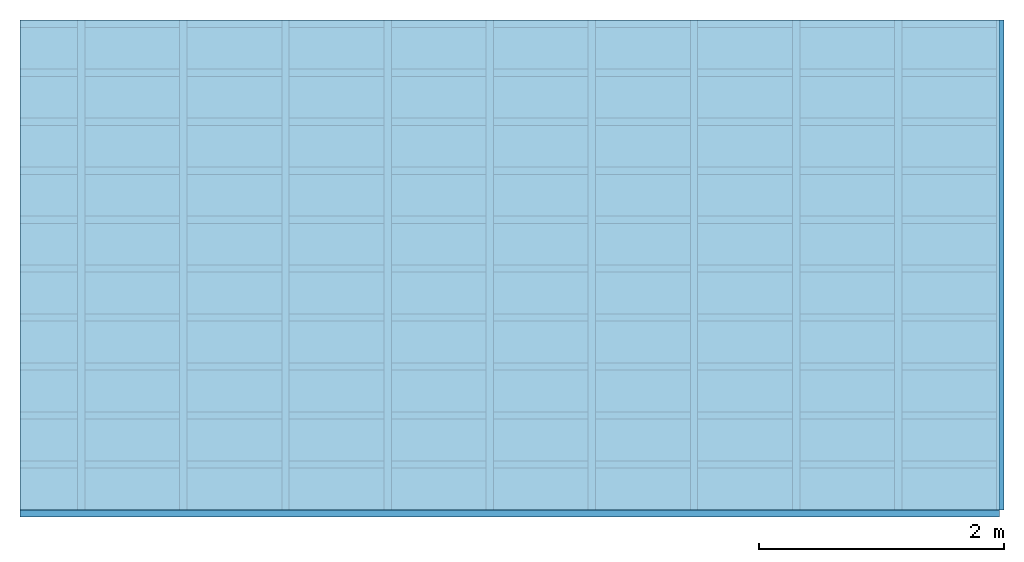
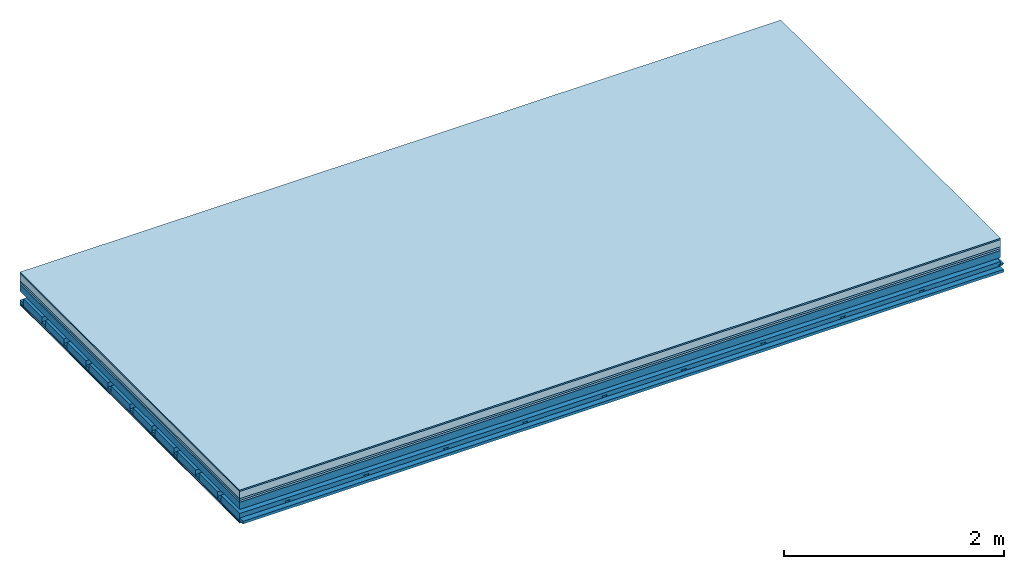
# One storey: 7 plates, 4 members, 1 element without a shape of its own.
"""IFC4 building model written with IfcOpenShell, lengths in metres."""

from ifc_helpers import new_model, si_unit, derived_unit, direction, frame, frame_2d, origin, origin_with_axes, place, context, project, spatial, polyline, rectangle, outline, extrude, material, layer, layer_set, type_object, element, aggregate, save


model = new_model("IFC4")

# Units and contexts
plan_context = context("Plan", 3, precision=1e-05, world=origin(), true_north=direction((0.0, 1.0)))
model_context = context("Model", 3, precision=1e-05, world=origin(), true_north=direction((0.0, 1.0)))
ifc_project = project(units=[si_unit("LENGTHUNIT", "METRE"), derived_unit("SOUNDPRESSUREUNIT", [(si_unit("PRESSUREUNIT", "PASCAL", prefix="MICRO"), 0)]), si_unit("ENERGYUNIT", "JOULE", prefix="MEGA"), si_unit("MASSUNIT", "GRAM", prefix="KILO"), derived_unit("THERMALTRANSMITTANCEUNIT", [(si_unit("POWERUNIT", "WATT"), 1), (si_unit("AREAUNIT", "SQUARE_METRE"), -1), (si_unit("THERMODYNAMICTEMPERATUREUNIT", "KELVIN"), -1)]), derived_unit("AREADENSITYUNIT", [(si_unit("MASSUNIT", "GRAM", prefix="KILO"), 1), (si_unit("AREAUNIT", "SQUARE_METRE"), -1)]), derived_unit("USERDEFINED", [(si_unit("ENERGYUNIT", "JOULE", prefix="MEGA"), 1), (si_unit("AREAUNIT", "SQUARE_METRE"), -1)])], contexts=[plan_context, model_context])

# Site, building, storey
site = spatial("IfcSite", under=ifc_project)
building_placement = place(None, origin())
building = spatial("IfcBuilding", under=site, at=building_placement)
storey_placement = place(building_placement, origin())
storey = spatial("IfcBuildingStorey", under=building, at=storey_placement)

# Slab, members, plates
ifc_material_1 = material(Category="11.013")
ifc_layer_1 = layer(ifc_material_1, 0.015, Name="Flooring")
ifc_material_2 = material(Name="Cement screed", Category="04.006")
ifc_layer_2 = layer(ifc_material_2, 0.08, Name="On-material")
ifc_material_3 = material(Name="Wood fiber generic product", Category="10.009")
ifc_layer_3 = layer(ifc_material_3, 0.02, Name="Impact sound insulation")
ifc_material_4 = material(Category="10.004")
ifc_layer_4 = layer(ifc_material_4, 0.02, Name="Additional insulation")
ifc_material_5 = material(Name="no composite action")
ifc_layer_5 = layer(ifc_material_5, 0.0, Name="Bond")
ifc_layer_6 = layer(None, 0.08, Name="Supporting structure")
ifc_layer_7 = layer(ifc_material_5, 0.0, Name="Bond")
ifc_layer_8 = layer(None, 0.095, Name="Coupling")
ifc_layer_9 = layer(None, 0.03, Name="Battens / profiles")
ifc_material_6 = material(Name="Plasterboard type A", Category="03.008")
ifc_layer_10 = layer(ifc_material_6, 0.0125, Name="Ceiling covering 1st layer")
ifc_layer_11 = layer(ifc_material_6, 0.0125, Name="Ceiling covering layer 2")
ifc_material_7 = material(Category="04.001")
ifc_layer_12 = layer(ifc_material_7, 0.003, Name="Surface / treatment")
ifc_layer_set = layer_set([ifc_layer_1, ifc_layer_2, ifc_layer_3, ifc_layer_4, ifc_layer_5, ifc_layer_6, ifc_layer_7, ifc_layer_8, ifc_layer_9, ifc_layer_10, ifc_layer_11, ifc_layer_12])
slab_type = type_object("IfcSlabType", Name="A2148", PredefinedType="NOTDEFINED", material=ifc_layer_set)
slab_placement = place(None, frame((0.0, 0.0, 0.0), z_axis=(0.0, 0.0, -1.0), x_axis=(1.0, 0.0, 0.0)))
slab = element("IfcSlab", 1, at=slab_placement, inside=storey, type_object=slab_type, material=ifc_layer_set, Name="Slab #1")
ifc_material_8 = material(Name="Solid timber panel")
member_1_placement = place(slab_placement, origin())
member_1 = element("IfcMember", 2, at=member_1_placement, material=ifc_material_8, Name="Supporting structure", context=plan_context, shape_type="SweptSolid", body=[
    extrude(rectangle(XDim=1.0, YDim=0.08, at=frame_2d((0.5, 0.04), x_axis=(1.0, 0.0))), frame((0.0, 4.0, 0.135), z_axis=(0.0, -1.0, 0.0), x_axis=(1.0, 0.0, 0.0)), (0.0, 0.0, 1.0), 4.0),
    extrude(rectangle(XDim=1.0, YDim=0.08, at=frame_2d((0.5, 0.04), x_axis=(1.0, 0.0))), frame((1.0, 4.0, 0.135), z_axis=(0.0, -1.0, 0.0), x_axis=(1.0, 0.0, 0.0)), (0.0, 0.0, 1.0), 4.0),
    extrude(rectangle(XDim=1.0, YDim=0.08, at=frame_2d((0.5, 0.04), x_axis=(1.0, 0.0))), frame((2.0, 4.0, 0.135), z_axis=(0.0, -1.0, 0.0), x_axis=(1.0, 0.0, 0.0)), (0.0, 0.0, 1.0), 4.0),
    extrude(rectangle(XDim=1.0, YDim=0.08, at=frame_2d((0.5, 0.04), x_axis=(1.0, 0.0))), frame((3.0, 4.0, 0.135), z_axis=(0.0, -1.0, 0.0), x_axis=(1.0, 0.0, 0.0)), (0.0, 0.0, 1.0), 4.0),
    extrude(rectangle(XDim=1.0, YDim=0.08, at=frame_2d((0.5, 0.04), x_axis=(1.0, 0.0))), frame((4.0, 4.0, 0.135), z_axis=(0.0, -1.0, 0.0), x_axis=(1.0, 0.0, 0.0)), (0.0, 0.0, 1.0), 4.0),
    extrude(rectangle(XDim=1.0, YDim=0.08, at=frame_2d((0.5, 0.04), x_axis=(1.0, 0.0))), frame((5.0, 4.0, 0.135), z_axis=(0.0, -1.0, 0.0), x_axis=(1.0, 0.0, 0.0)), (0.0, 0.0, 1.0), 4.0),
    extrude(rectangle(XDim=1.0, YDim=0.08, at=frame_2d((0.5, 0.04), x_axis=(1.0, 0.0))), frame((6.0, 4.0, 0.135), z_axis=(0.0, -1.0, 0.0), x_axis=(1.0, 0.0, 0.0)), (0.0, 0.0, 1.0), 4.0),
    extrude(rectangle(XDim=1.0, YDim=0.08, at=frame_2d((0.5, 0.04), x_axis=(1.0, 0.0))), frame((7.0, 4.0, 0.135), z_axis=(0.0, -1.0, 0.0), x_axis=(1.0, 0.0, 0.0)), (0.0, 0.0, 1.0), 4.0),
])
ifc_material_9 = material()
member_2_placement = place(slab_placement, origin())
member_2 = element("IfcMember", 3, at=member_2_placement, material=ifc_material_9, Name="Coupling", context=plan_context, shape_type="SweptSolid", body=[
    extrude(outline(polyline([(0.0, 0.0), (0.06, 0.0), (0.04, 0.02), (0.02, 0.02), (0.0, 0.0)])), frame((0.47, 4.0, 0.29), z_axis=(0.0, -1.0, 0.0), x_axis=(1.0, 0.0, 0.0)), (0.0, 0.0, 1.0), 4.0),
    extrude(outline(polyline([(0.0, 0.0), (0.06, 0.0), (0.04, 0.02), (0.02, 0.02), (0.0, 0.0)])), frame((1.304, 4.0, 0.29), z_axis=(0.0, -1.0, 0.0), x_axis=(1.0, 0.0, 0.0)), (0.0, 0.0, 1.0), 4.0),
    extrude(outline(polyline([(0.0, 0.0), (0.06, 0.0), (0.04, 0.02), (0.02, 0.02), (0.0, 0.0)])), frame((2.138, 4.0, 0.29), z_axis=(0.0, -1.0, 0.0), x_axis=(1.0, 0.0, 0.0)), (0.0, 0.0, 1.0), 4.0),
    extrude(outline(polyline([(0.0, 0.0), (0.06, 0.0), (0.04, 0.02), (0.02, 0.02), (0.0, 0.0)])), frame((2.972, 4.0, 0.29), z_axis=(0.0, -1.0, 0.0), x_axis=(1.0, 0.0, 0.0)), (0.0, 0.0, 1.0), 4.0),
    extrude(outline(polyline([(0.0, 0.0), (0.06, 0.0), (0.04, 0.02), (0.02, 0.02), (0.0, 0.0)])), frame((3.806, 4.0, 0.29), z_axis=(0.0, -1.0, 0.0), x_axis=(1.0, 0.0, 0.0)), (0.0, 0.0, 1.0), 4.0),
    extrude(outline(polyline([(0.0, 0.0), (0.06, 0.0), (0.04, 0.02), (0.02, 0.02), (0.0, 0.0)])), frame((4.64, 4.0, 0.29), z_axis=(0.0, -1.0, 0.0), x_axis=(1.0, 0.0, 0.0)), (0.0, 0.0, 1.0), 4.0),
    extrude(outline(polyline([(0.0, 0.0), (0.06, 0.0), (0.04, 0.02), (0.02, 0.02), (0.0, 0.0)])), frame((5.474, 4.0, 0.29), z_axis=(0.0, -1.0, 0.0), x_axis=(1.0, 0.0, 0.0)), (0.0, 0.0, 1.0), 4.0),
    extrude(outline(polyline([(0.0, 0.0), (0.06, 0.0), (0.04, 0.02), (0.02, 0.02), (0.0, 0.0)])), frame((6.308, 4.0, 0.29), z_axis=(0.0, -1.0, 0.0), x_axis=(1.0, 0.0, 0.0)), (0.0, 0.0, 1.0), 4.0),
    extrude(outline(polyline([(0.0, 0.0), (0.06, 0.0), (0.04, 0.02), (0.02, 0.02), (0.0, 0.0)])), frame((7.142, 4.0, 0.29), z_axis=(0.0, -1.0, 0.0), x_axis=(1.0, 0.0, 0.0)), (0.0, 0.0, 1.0), 4.0),
    extrude(outline(polyline([(0.0, 0.0), (0.06, 0.0), (0.04, 0.02), (0.02, 0.02), (0.0, 0.0)])), frame((7.976, 4.0, 0.29), z_axis=(0.0, -1.0, 0.0), x_axis=(1.0, 0.0, 0.0)), (0.0, 0.0, 1.0), 4.0),
])
member_3_placement = place(slab_placement, origin())
member_3 = element("IfcMember", 4, at=member_3_placement, material=ifc_material_9, Name="Battens / profiles", context=plan_context, shape_type="SweptSolid", body=[
    extrude(rectangle(XDim=0.06, YDim=0.03, at=frame_2d((0.03, 0.015), x_axis=(1.0, 0.0))), frame((0.0, 0.0, 0.31), z_axis=(1.0, 0.0, 0.0), x_axis=(0.0, 1.0, 0.0)), (0.0, 0.0, 1.0), 8.0),
    extrude(rectangle(XDim=0.06, YDim=0.03, at=frame_2d((0.03, 0.015), x_axis=(1.0, 0.0))), frame((0.0, 0.4, 0.31), z_axis=(1.0, 0.0, 0.0), x_axis=(0.0, 1.0, 0.0)), (0.0, 0.0, 1.0), 8.0),
    extrude(rectangle(XDim=0.06, YDim=0.03, at=frame_2d((0.03, 0.015), x_axis=(1.0, 0.0))), frame((0.0, 0.8, 0.31), z_axis=(1.0, 0.0, 0.0), x_axis=(0.0, 1.0, 0.0)), (0.0, 0.0, 1.0), 8.0),
    extrude(rectangle(XDim=0.06, YDim=0.03, at=frame_2d((0.03, 0.015), x_axis=(1.0, 0.0))), frame((0.0, 1.2, 0.31), z_axis=(1.0, 0.0, 0.0), x_axis=(0.0, 1.0, 0.0)), (0.0, 0.0, 1.0), 8.0),
    extrude(rectangle(XDim=0.06, YDim=0.03, at=frame_2d((0.03, 0.015), x_axis=(1.0, 0.0))), frame((0.0, 1.6, 0.31), z_axis=(1.0, 0.0, 0.0), x_axis=(0.0, 1.0, 0.0)), (0.0, 0.0, 1.0), 8.0),
    extrude(rectangle(XDim=0.06, YDim=0.03, at=frame_2d((0.03, 0.015), x_axis=(1.0, 0.0))), frame((0.0, 2.0, 0.31), z_axis=(1.0, 0.0, 0.0), x_axis=(0.0, 1.0, 0.0)), (0.0, 0.0, 1.0), 8.0),
    extrude(rectangle(XDim=0.06, YDim=0.03, at=frame_2d((0.03, 0.015), x_axis=(1.0, 0.0))), frame((0.0, 2.4, 0.31), z_axis=(1.0, 0.0, 0.0), x_axis=(0.0, 1.0, 0.0)), (0.0, 0.0, 1.0), 8.0),
    extrude(rectangle(XDim=0.06, YDim=0.03, at=frame_2d((0.03, 0.015), x_axis=(1.0, 0.0))), frame((0.0, 2.8, 0.31), z_axis=(1.0, 0.0, 0.0), x_axis=(0.0, 1.0, 0.0)), (0.0, 0.0, 1.0), 8.0),
    extrude(rectangle(XDim=0.06, YDim=0.03, at=frame_2d((0.03, 0.015), x_axis=(1.0, 0.0))), frame((0.0, 3.2, 0.31), z_axis=(1.0, 0.0, 0.0), x_axis=(0.0, 1.0, 0.0)), (0.0, 0.0, 1.0), 8.0),
    extrude(rectangle(XDim=0.06, YDim=0.03, at=frame_2d((0.03, 0.015), x_axis=(1.0, 0.0))), frame((0.0, 3.6, 0.31), z_axis=(1.0, 0.0, 0.0), x_axis=(0.0, 1.0, 0.0)), (0.0, 0.0, 1.0), 8.0),
    extrude(rectangle(XDim=0.06, YDim=0.03, at=frame_2d((0.03, 0.015), x_axis=(1.0, 0.0))), frame((0.0, 4.0, 0.31), z_axis=(1.0, 0.0, 0.0), x_axis=(0.0, 1.0, 0.0)), (0.0, 0.0, 1.0), 8.0),
])
ifc_material_10 = material()
member_4_placement = place(slab_placement, origin())
member_4 = element("IfcMember", 5, at=member_4_placement, material=ifc_material_10, Name="Cavity", context=plan_context, shape_type="SweptSolid", body=[
    extrude(rectangle(XDim=0.34, YDim=0.08, at=frame_2d((0.17, 0.04), x_axis=(1.0, 0.0))), frame((0.0, 0.06, 0.26), z_axis=(1.0, 0.0, 0.0), x_axis=(0.0, 1.0, 0.0)), (0.0, 0.0, 1.0), 8.0),
    extrude(rectangle(XDim=0.34, YDim=0.08, at=frame_2d((0.17, 0.04), x_axis=(1.0, 0.0))), frame((0.0, 0.46, 0.26), z_axis=(1.0, 0.0, 0.0), x_axis=(0.0, 1.0, 0.0)), (0.0, 0.0, 1.0), 8.0),
    extrude(rectangle(XDim=0.34, YDim=0.08, at=frame_2d((0.17, 0.04), x_axis=(1.0, 0.0))), frame((0.0, 0.86, 0.26), z_axis=(1.0, 0.0, 0.0), x_axis=(0.0, 1.0, 0.0)), (0.0, 0.0, 1.0), 8.0),
    extrude(rectangle(XDim=0.34, YDim=0.08, at=frame_2d((0.17, 0.04), x_axis=(1.0, 0.0))), frame((0.0, 1.26, 0.26), z_axis=(1.0, 0.0, 0.0), x_axis=(0.0, 1.0, 0.0)), (0.0, 0.0, 1.0), 8.0),
    extrude(rectangle(XDim=0.34, YDim=0.08, at=frame_2d((0.17, 0.04), x_axis=(1.0, 0.0))), frame((0.0, 1.66, 0.26), z_axis=(1.0, 0.0, 0.0), x_axis=(0.0, 1.0, 0.0)), (0.0, 0.0, 1.0), 8.0),
    extrude(rectangle(XDim=0.34, YDim=0.08, at=frame_2d((0.17, 0.04), x_axis=(1.0, 0.0))), frame((0.0, 2.06, 0.26), z_axis=(1.0, 0.0, 0.0), x_axis=(0.0, 1.0, 0.0)), (0.0, 0.0, 1.0), 8.0),
    extrude(rectangle(XDim=0.34, YDim=0.08, at=frame_2d((0.17, 0.04), x_axis=(1.0, 0.0))), frame((0.0, 2.46, 0.26), z_axis=(1.0, 0.0, 0.0), x_axis=(0.0, 1.0, 0.0)), (0.0, 0.0, 1.0), 8.0),
    extrude(rectangle(XDim=0.34, YDim=0.08, at=frame_2d((0.17, 0.04), x_axis=(1.0, 0.0))), frame((0.0, 2.86, 0.26), z_axis=(1.0, 0.0, 0.0), x_axis=(0.0, 1.0, 0.0)), (0.0, 0.0, 1.0), 8.0),
    extrude(rectangle(XDim=0.34, YDim=0.08, at=frame_2d((0.17, 0.04), x_axis=(1.0, 0.0))), frame((0.0, 3.26, 0.26), z_axis=(1.0, 0.0, 0.0), x_axis=(0.0, 1.0, 0.0)), (0.0, 0.0, 1.0), 8.0),
    extrude(rectangle(XDim=0.34, YDim=0.08, at=frame_2d((0.17, 0.04), x_axis=(1.0, 0.0))), frame((0.0, 3.66, 0.26), z_axis=(1.0, 0.0, 0.0), x_axis=(0.0, 1.0, 0.0)), (0.0, 0.0, 1.0), 8.0),
])
plate_1_placement = place(slab_placement, origin())
plate_1 = element("IfcPlate", 6, at=plate_1_placement, material=ifc_material_1, Name="Flooring", context=plan_context, shape_type="SweptSolid", body=[
    extrude(rectangle(XDim=8.0, YDim=4.0, at=frame_2d((4.0, 2.0), x_axis=(1.0, 0.0))), origin_with_axes(), (0.0, 0.0, 1.0), 0.015),
])
plate_2_placement = place(slab_placement, origin())
plate_2 = element("IfcPlate", 7, at=plate_2_placement, material=ifc_material_2, Name="On-material", context=plan_context, shape_type="SweptSolid", body=[
    extrude(rectangle(XDim=8.0, YDim=4.0, at=frame_2d((4.0, 2.0), x_axis=(1.0, 0.0))), frame((0.0, 0.0, 0.015), z_axis=(0.0, 0.0, 1.0), x_axis=(1.0, 0.0, 0.0)), (0.0, 0.0, 1.0), 0.08),
])
plate_3_placement = place(slab_placement, origin())
plate_3 = element("IfcPlate", 8, at=plate_3_placement, material=ifc_material_3, Name="Impact sound insulation", context=plan_context, shape_type="SweptSolid", body=[
    extrude(rectangle(XDim=8.0, YDim=4.0, at=frame_2d((4.0, 2.0), x_axis=(1.0, 0.0))), frame((0.0, 0.0, 0.095), z_axis=(0.0, 0.0, 1.0), x_axis=(1.0, 0.0, 0.0)), (0.0, 0.0, 1.0), 0.02),
])
plate_4_placement = place(slab_placement, origin())
plate_4 = element("IfcPlate", 9, at=plate_4_placement, material=ifc_material_4, Name="Additional insulation", context=plan_context, shape_type="SweptSolid", body=[
    extrude(rectangle(XDim=8.0, YDim=4.0, at=frame_2d((4.0, 2.0), x_axis=(1.0, 0.0))), frame((0.0, 0.0, 0.115), z_axis=(0.0, 0.0, 1.0), x_axis=(1.0, 0.0, 0.0)), (0.0, 0.0, 1.0), 0.02),
])
plate_5_placement = place(slab_placement, origin())
plate_5 = element("IfcPlate", 10, at=plate_5_placement, material=ifc_material_6, Name="Ceiling covering 1st layer", context=plan_context, shape_type="SweptSolid", body=[
    extrude(rectangle(XDim=8.0, YDim=4.0, at=frame_2d((4.0, 2.0), x_axis=(1.0, 0.0))), frame((0.0, 0.0, 0.34), z_axis=(0.0, 0.0, 1.0), x_axis=(1.0, 0.0, 0.0)), (0.0, 0.0, 1.0), 0.0125),
])
plate_6_placement = place(slab_placement, origin())
plate_6 = element("IfcPlate", 11, at=plate_6_placement, material=ifc_material_6, Name="Ceiling covering layer 2", context=plan_context, shape_type="SweptSolid", body=[
    extrude(rectangle(XDim=8.0, YDim=4.0, at=frame_2d((4.0, 2.0), x_axis=(1.0, 0.0))), frame((0.0, 0.0, 0.3525), z_axis=(0.0, 0.0, 1.0), x_axis=(1.0, 0.0, 0.0)), (0.0, 0.0, 1.0), 0.0125),
])
plate_7_placement = place(slab_placement, origin())
plate_7 = element("IfcPlate", 12, at=plate_7_placement, material=ifc_material_7, Name="Surface / treatment", context=plan_context, shape_type="SweptSolid", body=[
    extrude(rectangle(XDim=8.0, YDim=4.0, at=frame_2d((4.0, 2.0), x_axis=(1.0, 0.0))), frame((0.0, 0.0, 0.365), z_axis=(0.0, 0.0, 1.0), x_axis=(1.0, 0.0, 0.0)), (0.0, 0.0, 1.0), 0.003),
])
aggregate(slab, [plate_1, plate_2, plate_3, plate_4, member_1, member_2, member_3, member_4, plate_5, plate_6, plate_7])

save(model, "model.ifc")
